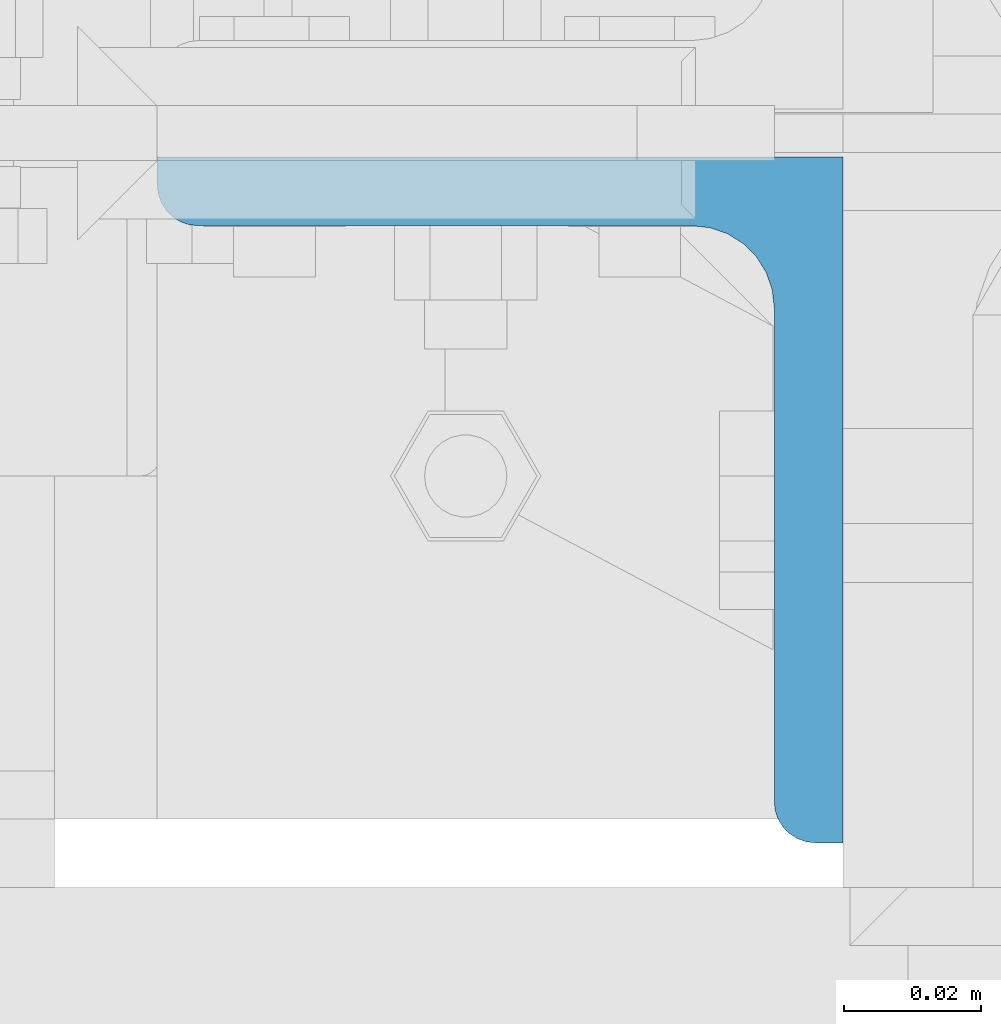
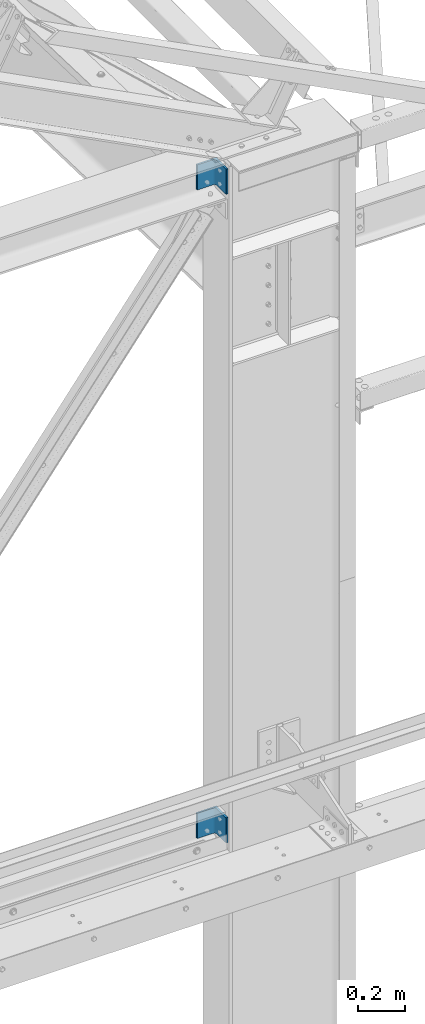
# One storey, part 29 of 496: 2 columns, 2 elements without a shape of their own.
"""IFC2X3 building model written with IfcOpenShell, lengths in millimetres."""

from ifc_helpers import new_model, si_unit, frame, origin_with_axes, origin_2d_with_axis, place, context, subcontext, project, spatial, l_section, extrude, material, type_object, element, aggregate, save


model = new_model("IFC2X3")

# Units and contexts
model_context = context("Model", 3, precision=1e-05, world=origin_with_axes())
body_context = subcontext(model_context, "Body", "Model", "MODEL_VIEW")
ifc_project = project(units=[si_unit("LENGTHUNIT", "METRE", prefix="MILLI"), si_unit("AREAUNIT", "SQUARE_METRE"), si_unit("VOLUMEUNIT", "CUBIC_METRE"), si_unit("MASSUNIT", "GRAM", prefix="KILO"), si_unit("TIMEUNIT", "SECOND"), si_unit("PLANEANGLEUNIT", "RADIAN"), si_unit("SOLIDANGLEUNIT", "STERADIAN"), si_unit("THERMODYNAMICTEMPERATUREUNIT", "DEGREE_CELSIUS"), si_unit("LUMINOUSINTENSITYUNIT", "LUMEN")], contexts=[model_context])

# Site, building, storey
site_placement = place(None, origin_with_axes())
site = spatial("IfcSite", under=ifc_project, at=site_placement, CompositionType="ELEMENT")
building_placement = place(site_placement, origin_with_axes())
building = spatial("IfcBuilding", under=site, at=building_placement, Name="Undefined", CompositionType="ELEMENT")
storey_placement = place(building_placement, origin_with_axes())
storey = spatial("IfcBuildingStorey", under=building, at=storey_placement, Name="Undefined", CompositionType="ELEMENT", Elevation=0.0)

# Assembly, column
assembly_1_placement = place(storey_placement, origin_with_axes())
assembly_1 = element("IfcElementAssembly", 1, at=assembly_1_placement, inside=storey, AssemblyPlace="NOTDEFINED", PredefinedType="NOTDEFINED")
ifc_material = material(Name="Undefined/S235-E24")
column_type = type_object("IfcColumnType", PredefinedType="NOTDEFINED")
column_1_placement = place(assembly_1_placement, frame((28529.9999133934, -53.500000000834, 8390.00002208709), z_axis=(0.0, 0.0, 1.0), x_axis=(-1.0, 0.0, 0.0)))
column_1 = element("IfcColumn", 2, at=column_1_placement, type_object=column_type, material=ifc_material, context=body_context, shape_type="SweptSolid", body=[
    extrude(l_section(Depth=100.0, Width=100.0, Thickness=10.0, FilletRadius=12.0, EdgeRadius=6.0, at=origin_2d_with_axis()), frame((0.0, 1.81898940354586e-12, 129.999999999999), z_axis=(0.0, 0.0, -1.0), x_axis=(0.0, 1.0, 0.0)), (0.0, 0.0, 1.0), 130.0),
])
aggregate(assembly_1, [column_1])

assembly_2_placement = place(storey_placement, origin_with_axes())
assembly_2 = element("IfcElementAssembly", 3, at=assembly_2_placement, inside=storey, AssemblyPlace="NOTDEFINED", PredefinedType="NOTDEFINED")
column_2_placement = place(assembly_2_placement, frame((28529.9999133934, -53.500000000834, 5030.00085394799), z_axis=(0.0, 0.0, 1.0), x_axis=(-1.0, 0.0, 0.0)))
column_2 = element("IfcColumn", 4, at=column_2_placement, type_object=column_type, material=ifc_material, context=body_context, shape_type="SweptSolid", body=[
    extrude(l_section(Depth=100.0, Width=100.0, Thickness=10.0, FilletRadius=12.0, EdgeRadius=6.0, at=origin_2d_with_axis()), frame((0.0, 1.81898940354586e-12, 129.999999999999), z_axis=(0.0, 0.0, -1.0), x_axis=(0.0, 1.0, 0.0)), (0.0, 0.0, 1.0), 130.0),
])
aggregate(assembly_2, [column_2])

save(model, "model.ifc")
